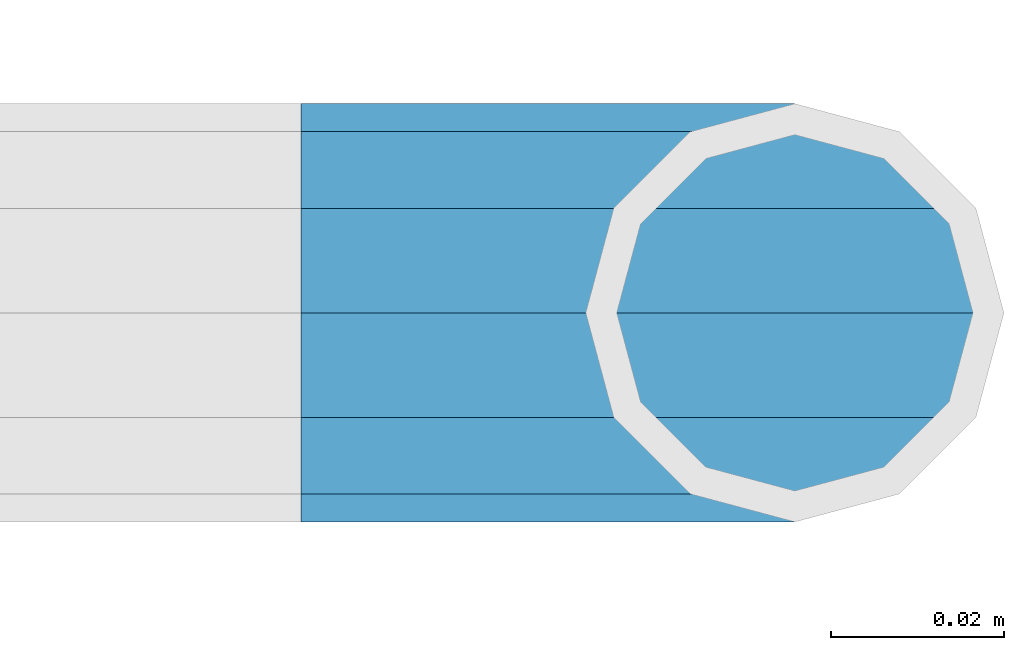
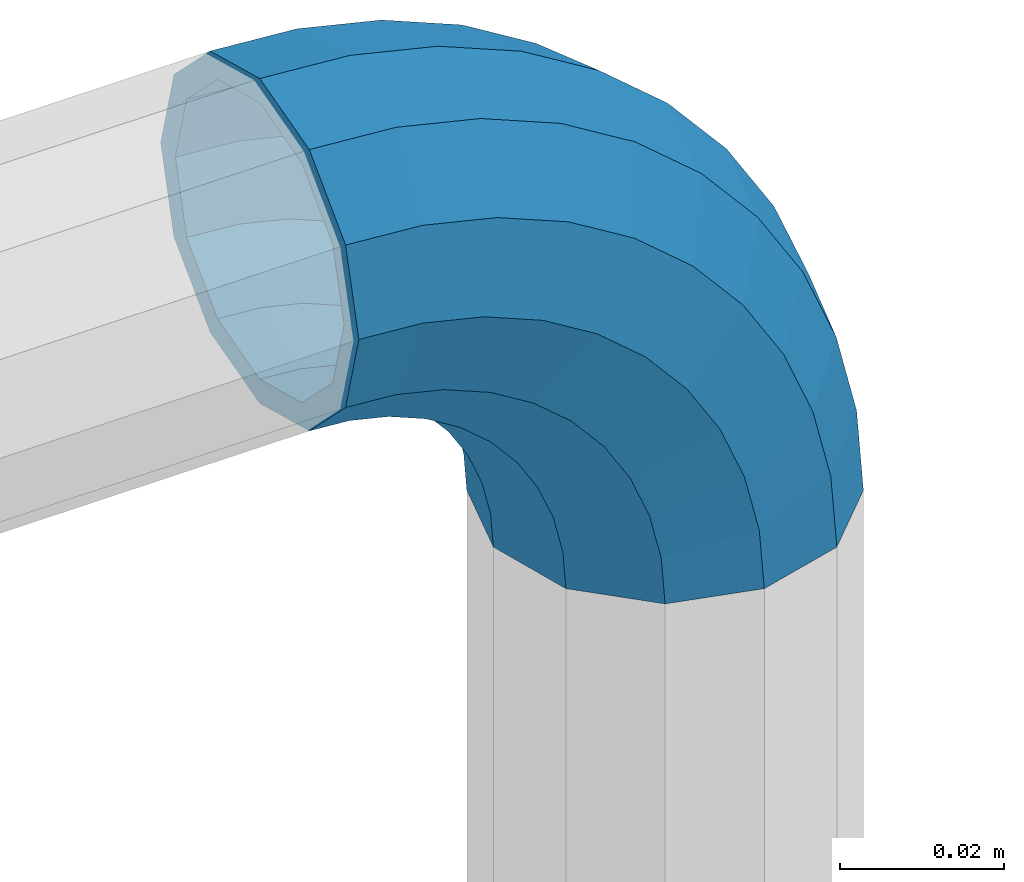
# One storey, part 180 of 247: 1 member.
"""IFC2X3 building model written with IfcOpenShell, lengths in millimetres."""

from ifc_helpers import new_model, si_unit, frame, origin_with_axes, place, context, subcontext, project, spatial, faceted_brep, material, type_object, element, save


model = new_model("IFC2X3")

# Units and contexts
model_context = context("Model", 3, precision=1e-05, world=origin_with_axes())
body_context = subcontext(model_context, "Body", "Model", "MODEL_VIEW")
ifc_project = project(units=[si_unit("LENGTHUNIT", "METRE", prefix="MILLI"), si_unit("AREAUNIT", "SQUARE_METRE"), si_unit("VOLUMEUNIT", "CUBIC_METRE"), si_unit("MASSUNIT", "GRAM", prefix="KILO"), si_unit("TIMEUNIT", "SECOND"), si_unit("PLANEANGLEUNIT", "RADIAN"), si_unit("SOLIDANGLEUNIT", "STERADIAN"), si_unit("THERMODYNAMICTEMPERATUREUNIT", "DEGREE_CELSIUS"), si_unit("LUMINOUSINTENSITYUNIT", "LUMEN")], contexts=[model_context])

# Site, building, storey
site_placement = place(None, origin_with_axes())
site = spatial("IfcSite", under=ifc_project, at=site_placement, CompositionType="ELEMENT")
building_placement = place(site_placement, origin_with_axes())
building = spatial("IfcBuilding", under=site, at=building_placement, Name="Standard", CompositionType="ELEMENT")
storey_placement = place(building_placement, origin_with_axes())
storey = spatial("IfcBuildingStorey", under=building, at=storey_placement, Name="Undefined", CompositionType="ELEMENT", Elevation=0.0)

# Member
ifc_material = material()
member_type = type_object("IfcMemberType", PredefinedType="NOTDEFINED")
member_placement = place(storey_placement, frame((30272.9462679207, 8941.85337247848, 935.350000000009), z_axis=(0.0, -0.999999999999548, -9.5100000000016e-07), x_axis=(0.707106845186484, -4.15000000539602e-07, -0.707106717186484)))
element("IfcMember", 1, at=member_placement, inside=storey, type_object=member_type, material=ifc_material, context=body_context, shape_type="Brep", body=[
    faceted_brep([(17.0766287656552, -17.0766287656515, 0.0), (14.7887943220521, -14.7887943220485, -12.0749999999998), (19.0945697419556, -11.1113146999705, -12.0749999999998), (20.9963409898264, -13.7288782624128, 0.0), (8.53831438282941, -8.53831438282577, -20.9145135013941), (13.8988340683936, -3.95999805533575, -20.9145135013941), (0.0, 3.63797880709171e-12, -24.1499999999996), (6.80132714696083, 5.80888215174127, -24.1499999999996), (-8.53831438282577, 8.53831438282941, -20.9145135013941), (-0.296179774468328, 15.5777623588219, -20.9145135013941), (-14.7887943220521, 14.7887943220558, -12.0749999999998), (-5.4919154480267, 22.7290790034531, -12.0749999999998), (-17.0766287656552, 17.0766287656588, 0.0), (-7.39368669590112, 25.3466425658989, 0.0), (-14.7887943220521, 14.7887943220558, 12.0749999999998), (-5.4919154480267, 22.7290790034531, 12.0749999999998), (-8.53831438282577, 8.53831438282941, 20.9145135013941), (-0.296179774468328, 15.5777623588219, 20.9145135013941), (0.0, 3.63797880709171e-12, 24.1499999999996), (6.80132714696083, 5.80888215174127, 24.1499999999996), (8.53831438282941, -8.53831438282577, 20.9145135013941), (13.8988340683936, -3.95999805533575, 20.9145135013941), (14.7887943220521, -14.7887943220485, 12.0749999999998), (19.0945697419556, -11.1113146999705, 12.0749999999998), (14.5310443533854, -14.5310443533817, 0.0), (12.5842535535485, -12.5842535535448, 10.2749999999996), (17.2620366843148, -8.58904933077429, 10.2749999999996), (18.8803140815726, -10.8164170826603, 0.0), (7.26552217669087, -7.26552217668723, 17.7968220477705), (12.8408206142667, -2.50376746545953, 17.7968220477705), (0.0, 3.63797880709171e-12, 20.5500000000002), (6.80132714696083, 5.80888215174127, 20.5500000000002), (-7.26552217669087, 7.2655221766945, 17.7968220477705), (0.761833679654956, 14.1215317689421, 17.7968220477705), (-12.5842535535485, 12.5842535535521, 10.2749999999996), (-3.65938239038951, 20.2068136342532, 10.2749999999996), (-14.5310443533817, 14.5310443533854, 0.0), (-5.27765978764728, 22.4341813861465, 0.0), (-12.5842535535485, 12.5842535535521, -10.2749999999996), (-3.65938239038951, 20.2068136342532, -10.2749999999996), (-7.26552217669087, 7.2655221766945, -17.7968220477705), (0.761833679654956, 14.1215317689421, -17.7968220477705), (0.0, 3.63797880709171e-12, -20.5500000000002), (6.80132714696083, 5.80888215174127, -20.5500000000002), (7.26552217669087, -7.26552217668723, -17.7968220477705), (12.8408206142667, -2.50376746545953, -17.7968220477705), (12.5842535535485, -12.5842535535448, -10.2749999999996), (17.2620366843148, -8.58904933077429, -10.2749999999996), (23.922618478784, -8.15268262886457, -12.0749999999998), (25.3914986111849, -11.0355222080434, 0.0), (19.9095633268335, -0.276618428470101, -20.9145135013941), (14.4276280424783, 10.4822853511068, -24.1499999999996), (8.94569275812319, 21.2411891306838, -20.9145135013941), (4.93263760616901, 29.1172533310746, -12.0749999999998), (3.46375747376806, 32.0000929102534, 0.0), (4.93263760616901, 29.1172533310746, 12.0749999999998), (8.94569275812319, 21.2411891306838, 20.9145135013941), (14.4276280424783, 10.4822853511068, 24.1499999999996), (19.9095633268335, -0.276618428470101, 20.9145135013941), (23.922618478784, -8.15268262886457, 12.0749999999998), (22.5072161777207, -5.37479920327678, 10.2749999999996), (23.7571328121303, -7.82789872096328, 0.0), (19.0923804273007, 1.32719331506814, 17.7968220477705), (14.4276280424783, 10.4822853511068, 20.5500000000002), (9.76287565765597, 19.6373773871455, 17.7968220477705), (6.34803990723594, 26.3393699054905, 10.2749999999996), (5.09812327282998, 28.7924694231733, 0.0), (6.34803990723594, 26.3393699054905, -10.2749999999996), (9.76287565765597, 19.6373773871455, -17.7968220477705), (14.4276280424783, 10.4822853511068, -20.5500000000002), (19.0923804273007, 1.32719331506814, -17.7968220477705), (22.5072161777207, -5.37479920327678, -10.2749999999996), (29.1540579492757, -5.98574944944994, -12.0749999999998), (30.1538782624157, -9.0628799673359, 0.0), (26.4224980553372, 2.42112746692874, -20.9145135013941), (22.6911178482587, 13.9051349011934, -24.1499999999996), (18.9597376411839, 25.3891423354544, -20.9145135013941), (16.228177747249, 33.7960192518367, -12.0749999999998), (15.2283574341054, 36.873149769719, 0.0), (16.228177747249, 33.7960192518367, 12.0749999999998), (18.9597376411839, 25.3891423354544, 20.9145135013941), (22.6911178482587, 13.9051349011934, 24.1499999999996), (26.4224980553372, 2.42112746692874, 20.9145135013941), (29.1540579492757, -5.98574944944994, 12.0749999999998), (28.190638306889, -3.02064867668378, 10.2749999999996), (29.0414170826662, -5.63907650866895, 0.0), (25.8662674654624, 4.13302919626221, 17.7968220477705), (22.6911178482587, 13.9051349011934, 20.5500000000002), (19.5159682310587, 23.6772406061282, 17.7968220477705), (17.1915973896357, 30.8309184790705, 10.2749999999996), (16.3408186138549, 33.4493463110593, 0.0), (17.1915973896357, 30.8309184790705, -10.2749999999996), (19.5159682310587, 23.6772406061282, -17.7968220477705), (22.6911178482587, 13.9051349011934, -20.5500000000002), (25.8662674654624, 4.13302919626221, -17.7968220477705), (28.190638306889, -3.02064867668378, -10.2749999999996), (34.660072751507, -4.66387224825303, -12.0749999999998), (35.1662143510621, -7.85952453907885, 0.0), (33.2772681857023, 4.06681217360529, -20.9145135013941), (31.3883220203388, 15.9931488862931, -24.1499999999996), (29.499375854979, 27.9194855989772, -20.9145135013941), (28.1165712891707, 36.6501700208391, -12.0749999999998), (27.6104296896192, 39.8458223116686, 0.0), (28.1165712891707, 36.6501700208391, 12.0749999999998), (29.499375854979, 27.9194855989772, 20.9145135013941), (31.3883220203388, 15.9931488862931, 24.1499999999996), (33.2772681857023, 4.06681217360529, 20.9145135013941), (34.660072751507, -4.66387224825303, 12.0749999999998), (34.1723583567982, -1.58456474993727, 10.2749999999996), (34.6030502769172, -4.30384651293571, 0.0), (32.995686148628, 5.84465118667504, 17.7968220477705), (31.3883220203388, 15.9931488862931, 20.5500000000002), (29.7809578920533, 26.1416465859074, 17.7968220477705), (28.6042856838794, 33.5708625225234, 10.2749999999996), (28.1735937637641, 36.2901442855255, 0.0), (28.6042856838794, 33.5708625225234, -10.2749999999996), (29.7809578920533, 26.1416465859074, -17.7968220477705), (31.3883220203388, 15.9931488862931, -20.5500000000002), (32.995686148628, 5.84465118667504, -17.7968220477705), (34.1723583567982, -1.58456474993727, -10.2749999999996), (40.3050865276309, -4.21960002902415, -12.0749999999998), (40.3050865276346, -7.45508652763237, 0.0), (40.3050865276309, 4.61991347236835, -20.9145135013941), (40.3050865276346, 16.6949134723691, -24.1499999999996), (40.3050865276309, 28.7699134723698, -20.9145135013941), (40.3050865276309, 37.6094269737623, -12.0749999999998), (40.3050865276346, 40.8449134723705, 0.0), (40.3050865276309, 37.6094269737623, 12.0749999999998), (40.3050865276309, 28.7699134723698, 20.9145135013941), (40.3050865276346, 16.6949134723691, 24.1499999999996), (40.3050865276309, 4.61991347236835, 20.9145135013941), (40.3050865276309, -4.21960002902415, 12.0749999999998), (40.3050865276346, -1.10190857540147, 10.2749999999996), (40.3050865276309, -3.85508652763019, 0.0), (40.3050865276346, 6.41991347236763, 17.7968220477705), (40.3050865276346, 16.6949134723691, 20.5500000000002), (40.3050865276346, 26.9699134723705, 17.7968220477705), (40.3050865276346, 34.4917355201396, 10.2749999999996), (40.3050865276309, 37.2449134723684, 0.0), (40.3050865276346, 34.4917355201396, -10.2749999999996), (40.3050865276346, 26.9699134723705, -17.7968220477705), (40.3050865276346, 16.6949134723691, -20.5500000000002), (40.3050865276346, 6.41991347236763, -17.7968220477705), (40.3050865276346, -1.10190857540147, -10.2749999999996), (45.9501003037585, -4.66387224825667, -12.0749999999998), (45.443958704207, -7.85952453907885, 0.0), (47.3329048695668, 4.06681217360529, -20.9145135013941), (49.2218510349267, 15.9931488862894, -24.1499999999996), (51.1107972002865, 27.9194855989808, -20.9145135013941), (52.4936017660912, 36.6501700208391, -12.0749999999998), (52.9997433656463, 39.845822311665, 0.0), (52.4936017660912, 36.6501700208391, 12.0749999999998), (51.1107972002865, 27.9194855989808, 20.9145135013941), (49.2218510349267, 15.9931488862894, 24.1499999999996), (47.3329048695668, 4.06681217360529, 20.9145135013941), (45.9501003037585, -4.66387224825667, 12.0749999999998), (46.4378146984673, -1.58456474993363, 10.2749999999996), (46.0071227783483, -4.30384651293934, 0.0), (47.6144869066338, 5.84465118667504, 17.7968220477705), (49.2218510349267, 15.9931488862894, 20.5500000000002), (50.8292151632122, 26.1416465859038, 17.7968220477705), (52.0058873713861, 33.5708625225197, 10.2749999999996), (52.4365792915014, 36.2901442855218, 0.0), (52.0058873713861, 33.5708625225197, -10.2749999999996), (50.8292151632122, 26.1416465859038, -17.7968220477705), (49.2218510349267, 15.9931488862894, -20.5500000000002), (47.6144869066338, 5.84465118667504, -17.7968220477705), (46.4378146984673, -1.58456474993363, -10.2749999999996), (51.4561151059934, -5.98574944944994, -12.0749999999998), (50.4562947928498, -9.06287996733226, 0.0), (54.1876749999246, 2.42112746692874, -20.9145135013941), (57.9190552070031, 13.9051349011934, -24.1499999999996), (61.6504354140816, 25.389142335458, -20.9145135013941), (64.3819953080201, 33.7960192518367, -12.0749999999998), (65.3818156211564, 36.873149769719, 0.0), (64.3819953080201, 33.7960192518367, 12.0749999999998), (61.6504354140816, 25.389142335458, 20.9145135013941), (57.9190552070031, 13.9051349011934, 24.1499999999996), (54.1876749999246, 2.42112746692874, 20.9145135013941), (51.4561151059934, -5.98574944944994, 12.0749999999998), (52.4195347483801, -3.02064867668378, 10.2749999999996), (51.5687559725993, -5.63907650867259, 0.0), (54.743905589803, 4.13302919625858, 17.7968220477705), (57.9190552070031, 13.9051349011934, 20.5500000000002), (61.0942048242068, 23.6772406061245, 17.7968220477705), (63.4185756656334, 30.8309184790705, 10.2749999999996), (64.2693544414105, 33.4493463110557, 0.0), (63.4185756656334, 30.8309184790705, -10.2749999999996), (61.0942048242068, 23.6772406061245, -17.7968220477705), (57.9190552070031, 13.9051349011934, -20.5500000000002), (54.743905589803, 4.13302919625858, -17.7968220477705), (52.4195347483801, -3.02064867668378, -10.2749999999996), (56.6875545764815, -8.15268262886093, -12.0749999999998), (55.2186744440769, -11.0355222080434, 0.0), (60.700609728432, -0.276618428466463, -20.9145135013941), (66.1825450127908, 10.4822853511068, -24.1499999999996), (71.6644802971423, 21.2411891306801, -20.9145135013941), (75.6775354490928, 29.1172533310746, -12.0749999999998), (77.1464155814938, 32.0000929102534, 0.0), (75.6775354490928, 29.1172533310746, 12.0749999999998), (71.6644802971423, 21.2411891306801, 20.9145135013941), (66.1825450127908, 10.4822853511068, 24.1499999999996), (60.700609728432, -0.276618428466463, 20.9145135013941), (56.6875545764815, -8.15268262886093, 12.0749999999998), (58.1029568775448, -5.37479920327314, 10.2749999999996), (56.8530402431388, -7.82789872096328, 0.0), (61.5177926279612, 1.32719331506814, 17.7968220477705), (66.1825450127908, 10.4822853511068, 20.5500000000002), (70.8472973976095, 19.6373773871419, 17.7968220477705), (74.2621331480295, 26.3393699054868, 10.2749999999996), (75.5120497824355, 28.792469423177, 0.0), (74.2621331480295, 26.3393699054868, -10.2749999999996), (70.8472973976095, 19.6373773871419, -17.7968220477705), (66.1825450127908, 10.4822853511068, -20.5500000000002), (61.5177926279612, 1.32719331506814, -17.7968220477705), (58.1029568775448, -5.37479920327314, -10.2749999999996), (61.5156033133135, -11.1113146999705, -12.0749999999998), (59.6138320654427, -13.7288782624128, 0.0), (66.7113389868719, -3.95999805533938, -20.9145135013941), (73.8088459083046, 5.80888215174491, -24.1499999999996), (80.9063528297338, 15.5777623588183, -20.9145135013941), (86.1020885032958, 22.7290790034531, -12.0749999999998), (88.0038597511666, 25.3466425658953, 0.0), (86.1020885032958, 22.7290790034531, 12.0749999999998), (80.9063528297338, 15.5777623588183, 20.9145135013941), (73.8088459083046, 5.80888215174491, 24.1499999999996), (66.7113389868719, -3.95999805533938, 20.9145135013941), (61.5156033133135, -11.1113146999705, 12.0749999999998), (63.3481363709507, -8.58904933077065, 10.2749999999996), (61.7298589736929, -10.816417082664, 0.0), (67.7693524410024, -2.50376746545953, 17.7968220477705), (73.8088459083046, 5.80888215174491, 20.5500000000002), (79.8483393756105, 14.1215317689457, 17.7968220477705), (84.2695554456586, 20.2068136342532, 10.2749999999996), (85.8878328429164, 22.4341813861465, 0.0), (84.2695554456586, 20.2068136342532, -10.2749999999996), (79.8483393756105, 14.1215317689457, -17.7968220477705), (73.8088459083046, 5.80888215174491, -20.5500000000002), (67.7693524410024, -2.50376746545953, -17.7968220477705), (63.3481363709507, -8.58904933077065, -10.2749999999996), (65.8213787332134, -14.7887943220521, -12.0749999999998), (63.5335442896103, -17.0766287656552, 0.0), (72.0718586724397, -8.53831438282577, -20.9145135013941), (80.6101730552655, 0.0, -24.1499999999996), (89.1484874380949, 8.53831438282941, -20.9145135013941), (95.3989673773212, 14.7887943220558, -12.0749999999998), (97.6868018209243, 17.0766287656588, 0.0), (95.3989673773212, 14.7887943220558, 12.0749999999998), (89.1484874380949, 8.53831438282941, 20.9145135013941), (80.6101730552655, 0.0, 24.1499999999996), (72.0718586724397, -8.53831438282577, 20.9145135013941), (65.8213787332134, -14.7887943220521, 12.0749999999998), (68.025919501717, -12.5842535535485, 10.2749999999996), (66.0791287018837, -14.5310443533817, 0.0), (73.3446508785746, -7.26552217669087, 17.7968220477705), (80.6101730552655, 0.0, 20.5500000000002), (87.87569523196, 7.2655221766945, 17.7968220477705), (93.1944266088176, 12.5842535535521, 10.2749999999996), (95.1412174086508, 14.5310443533854, 0.0), (93.1944266088176, 12.5842535535521, -10.2749999999996), (87.87569523196, 7.2655221766945, -17.7968220477705), (80.6101730552655, 0.0, -20.5500000000002), (73.3446508785746, -7.26552217669087, -17.7968220477705), (68.025919501717, -12.5842535535485, -10.2749999999996)], [[[0, 1, 2, 3]], [[1, 4, 5, 2]], [[4, 6, 7, 5]], [[6, 8, 9, 7]], [[8, 10, 11, 9]], [[10, 12, 13, 11]], [[12, 14, 15, 13]], [[14, 16, 17, 15]], [[16, 18, 19, 17]], [[18, 20, 21, 19]], [[20, 22, 23, 21]], [[22, 0, 3, 23]], [[24, 25, 26, 27]], [[25, 28, 29, 26]], [[28, 30, 31, 29]], [[30, 32, 33, 31]], [[32, 34, 35, 33]], [[34, 36, 37, 35]], [[36, 38, 39, 37]], [[38, 40, 41, 39]], [[40, 42, 43, 41]], [[42, 44, 45, 43]], [[44, 46, 47, 45]], [[46, 24, 27, 47]], [[22, 20, 18, 16, 14, 12, 10, 8, 6, 4, 1, 0], [46, 44, 42, 40, 38, 36, 34, 32, 30, 28, 25, 24]], [[3, 2, 48, 49]], [[2, 5, 50, 48]], [[5, 7, 51, 50]], [[7, 9, 52, 51]], [[9, 11, 53, 52]], [[11, 13, 54, 53]], [[13, 15, 55, 54]], [[15, 17, 56, 55]], [[17, 19, 57, 56]], [[19, 21, 58, 57]], [[21, 23, 59, 58]], [[23, 3, 49, 59]], [[27, 26, 60, 61]], [[26, 29, 62, 60]], [[29, 31, 63, 62]], [[31, 33, 64, 63]], [[33, 35, 65, 64]], [[35, 37, 66, 65]], [[37, 39, 67, 66]], [[39, 41, 68, 67]], [[41, 43, 69, 68]], [[43, 45, 70, 69]], [[45, 47, 71, 70]], [[47, 27, 61, 71]], [[49, 48, 72, 73]], [[48, 50, 74, 72]], [[50, 51, 75, 74]], [[51, 52, 76, 75]], [[52, 53, 77, 76]], [[53, 54, 78, 77]], [[54, 55, 79, 78]], [[55, 56, 80, 79]], [[56, 57, 81, 80]], [[57, 58, 82, 81]], [[58, 59, 83, 82]], [[59, 49, 73, 83]], [[61, 60, 84, 85]], [[60, 62, 86, 84]], [[62, 63, 87, 86]], [[63, 64, 88, 87]], [[64, 65, 89, 88]], [[65, 66, 90, 89]], [[66, 67, 91, 90]], [[67, 68, 92, 91]], [[68, 69, 93, 92]], [[69, 70, 94, 93]], [[70, 71, 95, 94]], [[71, 61, 85, 95]], [[73, 72, 96, 97]], [[72, 74, 98, 96]], [[74, 75, 99, 98]], [[75, 76, 100, 99]], [[76, 77, 101, 100]], [[77, 78, 102, 101]], [[78, 79, 103, 102]], [[79, 80, 104, 103]], [[80, 81, 105, 104]], [[81, 82, 106, 105]], [[82, 83, 107, 106]], [[83, 73, 97, 107]], [[85, 84, 108, 109]], [[84, 86, 110, 108]], [[86, 87, 111, 110]], [[87, 88, 112, 111]], [[88, 89, 113, 112]], [[89, 90, 114, 113]], [[90, 91, 115, 114]], [[91, 92, 116, 115]], [[92, 93, 117, 116]], [[93, 94, 118, 117]], [[94, 95, 119, 118]], [[95, 85, 109, 119]], [[97, 96, 120, 121]], [[96, 98, 122, 120]], [[98, 99, 123, 122]], [[99, 100, 124, 123]], [[100, 101, 125, 124]], [[101, 102, 126, 125]], [[102, 103, 127, 126]], [[103, 104, 128, 127]], [[104, 105, 129, 128]], [[105, 106, 130, 129]], [[106, 107, 131, 130]], [[107, 97, 121, 131]], [[109, 108, 132, 133]], [[108, 110, 134, 132]], [[110, 111, 135, 134]], [[111, 112, 136, 135]], [[112, 113, 137, 136]], [[113, 114, 138, 137]], [[114, 115, 139, 138]], [[115, 116, 140, 139]], [[116, 117, 141, 140]], [[117, 118, 142, 141]], [[118, 119, 143, 142]], [[119, 109, 133, 143]], [[121, 120, 144, 145]], [[120, 122, 146, 144]], [[122, 123, 147, 146]], [[123, 124, 148, 147]], [[124, 125, 149, 148]], [[125, 126, 150, 149]], [[126, 127, 151, 150]], [[127, 128, 152, 151]], [[128, 129, 153, 152]], [[129, 130, 154, 153]], [[130, 131, 155, 154]], [[131, 121, 145, 155]], [[133, 132, 156, 157]], [[132, 134, 158, 156]], [[134, 135, 159, 158]], [[135, 136, 160, 159]], [[136, 137, 161, 160]], [[137, 138, 162, 161]], [[138, 139, 163, 162]], [[139, 140, 164, 163]], [[140, 141, 165, 164]], [[141, 142, 166, 165]], [[142, 143, 167, 166]], [[143, 133, 157, 167]], [[145, 144, 168, 169]], [[144, 146, 170, 168]], [[146, 147, 171, 170]], [[147, 148, 172, 171]], [[148, 149, 173, 172]], [[149, 150, 174, 173]], [[150, 151, 175, 174]], [[151, 152, 176, 175]], [[152, 153, 177, 176]], [[153, 154, 178, 177]], [[154, 155, 179, 178]], [[155, 145, 169, 179]], [[157, 156, 180, 181]], [[156, 158, 182, 180]], [[158, 159, 183, 182]], [[159, 160, 184, 183]], [[160, 161, 185, 184]], [[161, 162, 186, 185]], [[162, 163, 187, 186]], [[163, 164, 188, 187]], [[164, 165, 189, 188]], [[165, 166, 190, 189]], [[166, 167, 191, 190]], [[167, 157, 181, 191]], [[169, 168, 192, 193]], [[168, 170, 194, 192]], [[170, 171, 195, 194]], [[171, 172, 196, 195]], [[172, 173, 197, 196]], [[173, 174, 198, 197]], [[174, 175, 199, 198]], [[175, 176, 200, 199]], [[176, 177, 201, 200]], [[177, 178, 202, 201]], [[178, 179, 203, 202]], [[179, 169, 193, 203]], [[181, 180, 204, 205]], [[180, 182, 206, 204]], [[182, 183, 207, 206]], [[183, 184, 208, 207]], [[184, 185, 209, 208]], [[185, 186, 210, 209]], [[186, 187, 211, 210]], [[187, 188, 212, 211]], [[188, 189, 213, 212]], [[189, 190, 214, 213]], [[190, 191, 215, 214]], [[191, 181, 205, 215]], [[193, 192, 216, 217]], [[192, 194, 218, 216]], [[194, 195, 219, 218]], [[195, 196, 220, 219]], [[196, 197, 221, 220]], [[197, 198, 222, 221]], [[198, 199, 223, 222]], [[199, 200, 224, 223]], [[200, 201, 225, 224]], [[201, 202, 226, 225]], [[202, 203, 227, 226]], [[203, 193, 217, 227]], [[205, 204, 228, 229]], [[204, 206, 230, 228]], [[206, 207, 231, 230]], [[207, 208, 232, 231]], [[208, 209, 233, 232]], [[209, 210, 234, 233]], [[210, 211, 235, 234]], [[211, 212, 236, 235]], [[212, 213, 237, 236]], [[213, 214, 238, 237]], [[214, 215, 239, 238]], [[215, 205, 229, 239]], [[217, 216, 240, 241]], [[216, 218, 242, 240]], [[218, 219, 243, 242]], [[219, 220, 244, 243]], [[220, 221, 245, 244]], [[221, 222, 246, 245]], [[222, 223, 247, 246]], [[223, 224, 248, 247]], [[224, 225, 249, 248]], [[225, 226, 250, 249]], [[226, 227, 251, 250]], [[227, 217, 241, 251]], [[229, 228, 252, 253]], [[228, 230, 254, 252]], [[230, 231, 255, 254]], [[231, 232, 256, 255]], [[232, 233, 257, 256]], [[233, 234, 258, 257]], [[234, 235, 259, 258]], [[235, 236, 260, 259]], [[236, 237, 261, 260]], [[237, 238, 262, 261]], [[238, 239, 263, 262]], [[239, 229, 253, 263]], [[242, 243, 244, 245, 246, 247, 248, 249, 250, 251, 241, 240], [254, 255, 256, 257, 258, 259, 260, 261, 262, 263, 253, 252]]]),
])

save(model, "model.ifc")
